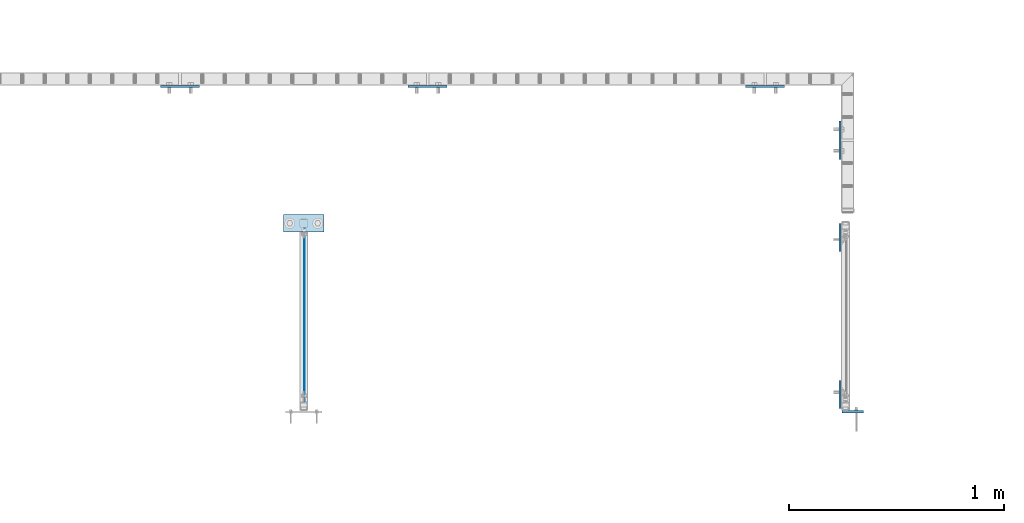
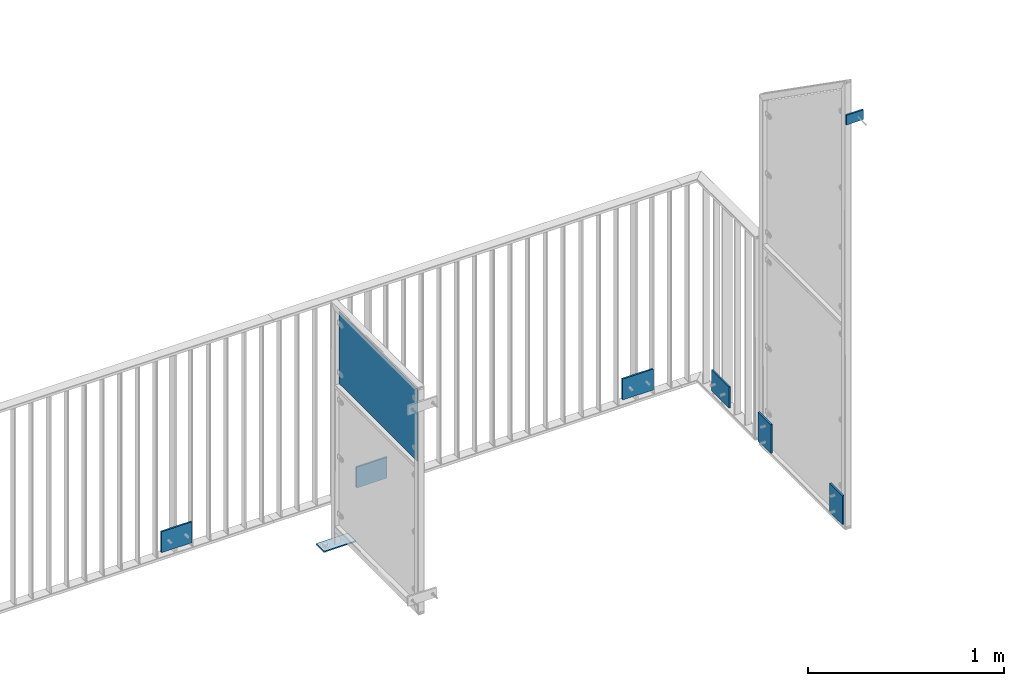
# One storey, part 53 of 156: 9 plates, 6 elements without a shape of their own.
"""IFC2X3 building model written with IfcOpenShell, lengths in millimetres."""

from ifc_helpers import new_model, si_unit, frame, origin_with_axes, origin_2d_with_axis, place, context, subcontext, project, spatial, polyline, rectangle, outline, extrude, material, type_object, element, aggregate, save


model = new_model("IFC2X3")

# Units and contexts
model_context = context("Model", 3, precision=1e-05, world=origin_with_axes())
body_context = subcontext(model_context, "Body", "Model", "MODEL_VIEW")
ifc_project = project(units=[si_unit("LENGTHUNIT", "METRE", prefix="MILLI"), si_unit("AREAUNIT", "SQUARE_METRE"), si_unit("VOLUMEUNIT", "CUBIC_METRE"), si_unit("MASSUNIT", "GRAM", prefix="KILO"), si_unit("TIMEUNIT", "SECOND"), si_unit("PLANEANGLEUNIT", "RADIAN"), si_unit("SOLIDANGLEUNIT", "STERADIAN"), si_unit("THERMODYNAMICTEMPERATUREUNIT", "DEGREE_CELSIUS"), si_unit("LUMINOUSINTENSITYUNIT", "LUMEN")], contexts=[model_context])

# Site, building, storey
site_placement = place(None, origin_with_axes())
site = spatial("IfcSite", under=ifc_project, at=site_placement, CompositionType="ELEMENT")
building_placement = place(site_placement, origin_with_axes())
building = spatial("IfcBuilding", under=site, at=building_placement, Name="Undefined", CompositionType="ELEMENT")
storey_placement = place(building_placement, origin_with_axes())
storey = spatial("IfcBuildingStorey", under=building, at=storey_placement, Name="Undefined", CompositionType="ELEMENT", Elevation=0.0)

# Assembly, plates
assembly_1_placement = place(storey_placement, origin_with_axes())
assembly_1 = element("IfcElementAssembly", 1, at=assembly_1_placement, inside=storey, AssemblyPlace="NOTDEFINED", PredefinedType="RIGID_FRAME")
ifc_material = material(Name="STEEL/S235JR")
plate_type_1 = type_object("IfcPlateType", PredefinedType="NOTDEFINED")
plate_1_placement = place(assembly_1_placement, frame((36489.9982910683, 20192.9965089796, 2942.50385412297), z_axis=(0.0, 0.99999999999886, -1.50999999973318e-06), x_axis=(0.0, -1.7160000020845e-06, -0.999999999998528)))
plate_1 = element("IfcPlate", 2, at=plate_1_placement, type_object=plate_type_1, material=ifc_material, context=body_context, shape_type="SweptSolid", body=[
    extrude(rectangle(XDim=10.0, YDim=130.0, at=origin_2d_with_axis()), frame((180.0, 0.0, 0.0), z_axis=(-1.0, 0.0, 0.0), x_axis=(0.0, -1.0, 0.0)), (0.0, 0.0, 1.0), 180.0),
])
plate_2_placement = place(assembly_1_placement, frame((36489.9982910683, 20923.0065844806, 2942.50385412297), z_axis=(0.0, -0.999999999998528, -1.71599999971061e-06), x_axis=(0.0, 1.73100000029081e-06, -0.999999999998502)))
plate_2 = element("IfcPlate", 3, at=plate_2_placement, type_object=plate_type_1, material=ifc_material, context=body_context, shape_type="SweptSolid", body=[
    extrude(rectangle(XDim=10.0, YDim=130.0, at=origin_2d_with_axis()), frame((180.0, 0.0, 0.0), z_axis=(-1.0, 0.0, 0.0), x_axis=(0.0, -1.0, 0.0)), (0.0, 0.0, 1.0), 180.0),
])

# Assembly, plate
assembly_2_placement = place(storey_placement, origin_with_axes())
assembly_2 = element("IfcElementAssembly", 4, at=assembly_2_placement, inside=storey, AssemblyPlace="NOTDEFINED", PredefinedType="RIGID_FRAME")
plate_3_placement = place(assembly_2_placement, frame((34664.6454415178, 21622.9919947809, 2852.5), z_axis=(0.0, 0.0, 1.0), x_axis=(-1.0, 0.0, 0.0)))
plate_3 = element("IfcPlate", 5, at=plate_3_placement, type_object=plate_type_1, material=ifc_material, context=body_context, shape_type="SweptSolid", body=[
    extrude(rectangle(XDim=10.0, YDim=130.0, at=origin_2d_with_axis()), frame((180.0, 0.0, 0.0), z_axis=(-1.0, 0.0, 0.0), x_axis=(0.0, -1.0, 0.0)), (0.0, 0.0, 1.0), 180.0),
])

assembly_3_placement = place(storey_placement, origin_with_axes())
assembly_3 = element("IfcElementAssembly", 6, at=assembly_3_placement, inside=storey, AssemblyPlace="NOTDEFINED", PredefinedType="RIGID_FRAME")
plate_4_placement = place(assembly_3_placement, frame((33515.3401831962, 21622.9919947809, 2852.5), z_axis=(0.0, 0.0, 1.0), x_axis=(-1.0, 0.0, 0.0)))
plate_4 = element("IfcPlate", 7, at=plate_4_placement, type_object=plate_type_1, material=ifc_material, context=body_context, shape_type="SweptSolid", body=[
    extrude(rectangle(XDim=10.0, YDim=130.0, at=origin_2d_with_axis()), frame((180.0, 0.0, 0.0), z_axis=(-1.0, 0.0, 0.0), x_axis=(0.0, -1.0, 0.0)), (0.0, 0.0, 1.0), 180.0),
])
aggregate(assembly_3, [plate_4])

assembly_4_placement = place(storey_placement, origin_with_axes())
assembly_4 = element("IfcElementAssembly", 8, at=assembly_4_placement, inside=storey, AssemblyPlace="NOTDEFINED", PredefinedType="RIGID_FRAME")
plate_5_placement = place(assembly_4_placement, frame((36489.9982910683, 21464.1507649865, 2852.5), z_axis=(0.0, 0.0, 1.0), x_axis=(0.0, -1.0, 0.0)))
plate_5 = element("IfcPlate", 9, at=plate_5_placement, type_object=plate_type_1, material=ifc_material, context=body_context, shape_type="SweptSolid", body=[
    extrude(rectangle(XDim=10.0, YDim=130.0, at=origin_2d_with_axis()), frame((180.0, 0.0, 0.0), z_axis=(-1.0, 0.0, 0.0), x_axis=(0.0, -1.0, 0.0)), (0.0, 0.0, 1.0), 180.0),
])
aggregate(assembly_4, [plate_5])

# Plate
plate_6_placement = place(assembly_2_placement, frame((36231.6668934273, 21622.9919947809, 2852.5), z_axis=(0.0, 0.0, 1.0), x_axis=(-1.0, 0.0, 0.0)))
plate_6 = element("IfcPlate", 10, at=plate_6_placement, type_object=plate_type_1, material=ifc_material, context=body_context, shape_type="SweptSolid", body=[
    extrude(rectangle(XDim=10.0, YDim=130.0, at=origin_2d_with_axis()), frame((180.0, 0.0, 0.0), z_axis=(-1.0, 0.0, 0.0), x_axis=(0.0, -1.0, 0.0)), (0.0, 0.0, 1.0), 180.0),
])

aggregate(assembly_2, [plate_3, plate_6])

# Assembly, plate
assembly_5_placement = place(storey_placement, origin_with_axes())
assembly_5 = element("IfcElementAssembly", 11, at=assembly_5_placement, inside=storey, AssemblyPlace="NOTDEFINED", PredefinedType="RIGID_FRAME")
plate_type_2 = type_object("IfcPlateType", PredefinedType="NOTDEFINED")
plate_7_placement = place(assembly_5_placement, frame((33905.0, 20988.2579449451, 2998.99577404583), z_axis=(0.0, -0.000195990999960145, 0.999999980793764), x_axis=(1.0, 0.0, 0.0)))
plate_7 = element("IfcPlate", 12, at=plate_7_placement, type_object=plate_type_2, material=ifc_material, context=body_context, shape_type="SweptSolid", body=[
    extrude(outline(polyline([(0.0, -40.0000000001091), (0.0, 40.0000000001091), (190.0, 40.0000000001091), (190.0, -40.0000000001091), (0.0, -40.0000000001091)])), frame((0.0, 0.0, -4.0), z_axis=(0.0, 0.0, 1.0), x_axis=(1.0, 0.0, 0.0)), (0.0, 0.0, 1.0), 8.0),
])
aggregate(assembly_5, [plate_7])

# Plate
plate_type_3 = type_object("IfcPlateType", PredefinedType="NOTDEFINED")
plate_8_placement = place(assembly_1_placement, frame((36597.9954376221, 20113.4532470703, 5289.3099999525), z_axis=(0.0, 0.0, 1.0), x_axis=(-1.0, 0.0, 0.0)))
plate_8 = element("IfcPlate", 13, at=plate_8_placement, type_object=plate_type_3, material=ifc_material, context=body_context, shape_type="SweptSolid", body=[
    extrude(rectangle(XDim=10.0, YDim=60.0, at=origin_2d_with_axis()), frame((100.0, 0.0, 0.0), z_axis=(-1.0, 0.0, 0.0), x_axis=(0.0, -1.0, 0.0)), (0.0, 0.0, 1.0), 100.0),
])

aggregate(assembly_1, [plate_8, plate_1, plate_2])

# Assembly, plate
assembly_6_placement = place(storey_placement, origin_with_axes())
assembly_6 = element("IfcElementAssembly", 14, at=assembly_6_placement, inside=storey, AssemblyPlace="NOTDEFINED", PredefinedType="RIGID_FRAME")
plate_type_4 = type_object("IfcPlateType", PredefinedType="NOTDEFINED")
plate_9_placement = place(assembly_6_placement, frame((34004.0, 20162.9576678344, 4229.99878707759), z_axis=(0.0, 0.0, 1.0), x_axis=(0.0, 1.0, 0.0)))
plate_9 = element("IfcPlate", 15, at=plate_9_placement, type_object=plate_type_4, material=ifc_material, context=body_context, shape_type="SweptSolid", body=[
    extrude(rectangle(XDim=3.0, YDim=450.0, at=origin_2d_with_axis()), frame((800.050991195178, 0.0, 0.0), z_axis=(-1.0, 0.0, 0.0), x_axis=(0.0, -1.0, 0.0)), (0.0, 0.0, 1.0), 800.05),
])
aggregate(assembly_6, [plate_9])

save(model, "model.ifc")
